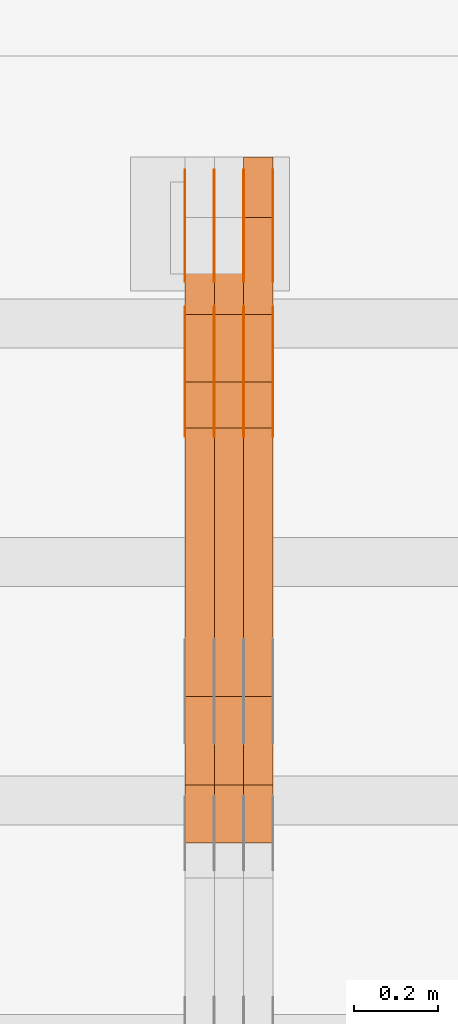
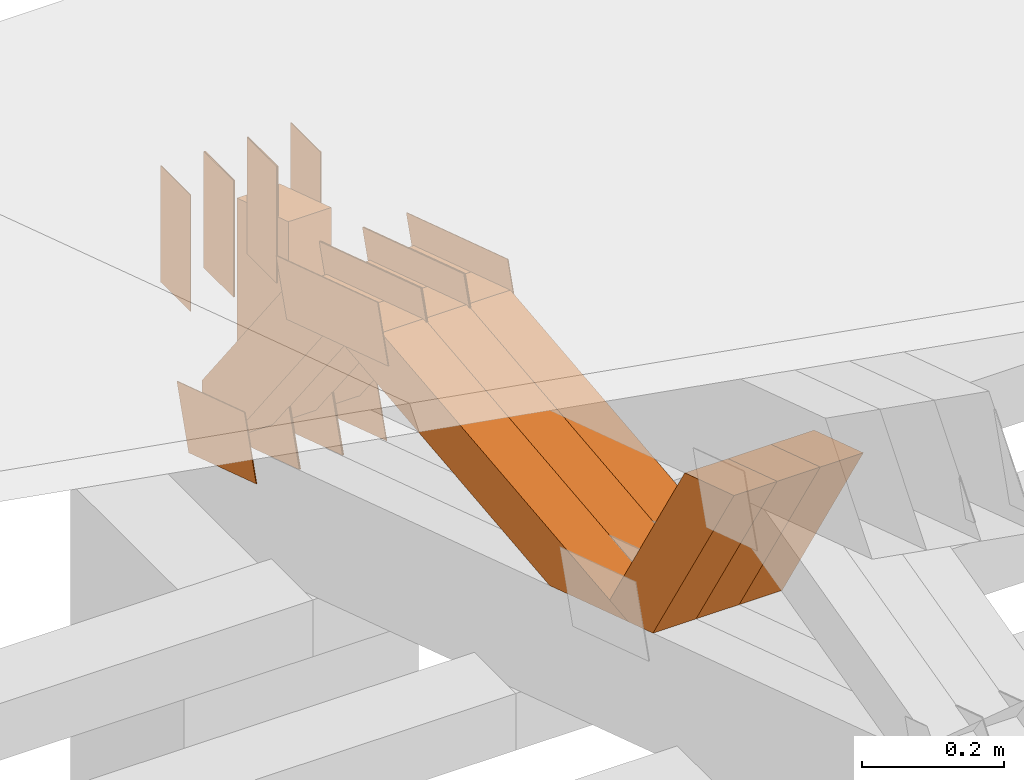
# One storey, part 219 of 385: 28 proxies.
"""IFC2X3 building model written with IfcOpenShell, lengths in millimetres."""

from ifc_helpers import new_model, entity, si_unit, converted_unit, derived_unit, direction, frame, frame_2d, origin, place, context, subcontext, project, spatial, polyline, rectangle, outline, extrude, source, transform, mapped, material, type_object, type_shapes, element, save


model = new_model("IFC2X3")

# Units and contexts
model_context = context("Model", 3, precision=0.01, world=origin(), true_north=direction((6.12303176911189e-17, 1.0)))
body_context = subcontext(model_context, "Body", "Model", "MODEL_VIEW")
ifc_project = project(units=[si_unit("LENGTHUNIT", "METRE", prefix="MILLI"), si_unit("AREAUNIT", "SQUARE_METRE"), si_unit("VOLUMEUNIT", "CUBIC_METRE"), converted_unit("PLANEANGLEUNIT", "DEGREE", entity("IfcRatioMeasure", 0.0174532925199433), si_unit("PLANEANGLEUNIT", "RADIAN"), dimensions=[0, 0, 0, 0, 0, 0, 0]), si_unit("MASSUNIT", "GRAM", prefix="KILO"), derived_unit("MASSDENSITYUNIT", [(si_unit("MASSUNIT", "GRAM", prefix="KILO"), 1), (si_unit("LENGTHUNIT", "METRE"), -3)]), si_unit("TIMEUNIT", "SECOND"), si_unit("FREQUENCYUNIT", "HERTZ"), si_unit("THERMODYNAMICTEMPERATUREUNIT", "DEGREE_CELSIUS"), derived_unit("THERMALTRANSMITTANCEUNIT", [(si_unit("MASSUNIT", "GRAM", prefix="KILO"), 1), (si_unit("THERMODYNAMICTEMPERATUREUNIT", "KELVIN"), -1), (si_unit("TIMEUNIT", "SECOND"), -3)]), derived_unit("VOLUMETRICFLOWRATEUNIT", [(si_unit("LENGTHUNIT", "METRE"), 3), (si_unit("TIMEUNIT", "SECOND"), -1)]), si_unit("ELECTRICCURRENTUNIT", "AMPERE"), si_unit("ELECTRICVOLTAGEUNIT", "VOLT"), si_unit("POWERUNIT", "WATT"), si_unit("FORCEUNIT", "NEWTON", prefix="KILO"), si_unit("ILLUMINANCEUNIT", "LUX"), si_unit("LUMINOUSFLUXUNIT", "LUMEN"), si_unit("LUMINOUSINTENSITYUNIT", "CANDELA"), derived_unit("USERDEFINED", [(si_unit("MASSUNIT", "GRAM", prefix="KILO"), -1), (si_unit("LENGTHUNIT", "METRE"), -2), (si_unit("TIMEUNIT", "SECOND"), 3), (si_unit("LUMINOUSFLUXUNIT", "LUMEN"), 1)]), derived_unit("LINEARVELOCITYUNIT", [(si_unit("LENGTHUNIT", "METRE"), 1), (si_unit("TIMEUNIT", "SECOND"), -1)]), si_unit("PRESSUREUNIT", "PASCAL"), derived_unit("USERDEFINED", [(si_unit("LENGTHUNIT", "METRE"), -2), (si_unit("MASSUNIT", "GRAM", prefix="KILO"), 1), (si_unit("TIMEUNIT", "SECOND"), -2)])], contexts=[model_context])

# Site, building, storey
site_placement = place(None, origin())
site = spatial("IfcSite", under=ifc_project, at=site_placement, CompositionType="ELEMENT")
building_placement = place(site_placement, origin())
building = spatial("IfcBuilding", under=site, at=building_placement, CompositionType="ELEMENT")
storey_placement = place(building_placement, origin())
storey = spatial("IfcBuildingStorey", under=building, at=storey_placement, Name="Default", CompositionType="ELEMENT", Elevation=0.0)

# Proxies
ifc_material_1 = material(Name="IfcSurfaceStyle #240494")
building_element_proxy_type_1 = type_object("IfcBuildingElementProxyType", PredefinedType="NOTDEFINED", material=ifc_material_1)
shared_shape_1 = source(origin(), body_context, "Body", "SweptSolid", [
    extrude(outline(polyline([(-100.000024997547, -54.0000105875654), (100.000088940899, -54.0000105875654), (99.9999100805868, 54.0000105875654), (-99.9999740239394, 54.0000105875654), (-100.000024997547, -54.0000105875654)])), frame((100.000088940899, 54.0000474633838, 0.0), z_axis=(0.0, 0.0, 1.0), x_axis=(-1.0, 0.0, 0.0)), (0.0, 0.0, 1.0), 1.3),
])
type_shapes(building_element_proxy_type_1, [shared_shape_1])
proxy_1_placement = place(building_placement, frame((18386.3, 26390.6212638563, 73.3227520411355), z_axis=(-1.0, 0.0, 0.0), x_axis=(0.0, -0.951056516295124, 0.309016994375039)))
element("IfcBuildingElementProxy", 1, at=proxy_1_placement, inside=storey, type_object=building_element_proxy_type_1, material=ifc_material_1, context=body_context, shape_type="MappedRepresentation", body=[
    mapped(shared_shape_1, transform((0.0, 0.0, 0.0), scale=1.0)),
])
ifc_material_2 = material(Name="IfcSurfaceStyle #240437")
building_element_proxy_type_2 = type_object("IfcBuildingElementProxyType", PredefinedType="NOTDEFINED", material=ifc_material_2)
shared_shape_2 = source(origin(), body_context, "Body", "SweptSolid", [
    extrude(outline(polyline([(-100.000024997547, -54.0000105875654), (100.000088940899, -54.0000105875654), (99.9999100805868, 54.0000105875654), (-99.9999740239394, 54.0000105875654), (-100.000024997547, -54.0000105875654)])), frame((100.000088940899, 54.0000474633838, 0.0), z_axis=(0.0, 0.0, 1.0), x_axis=(-1.0, 0.0, 0.0)), (0.0, 0.0, 1.0), 1.3),
])
type_shapes(building_element_proxy_type_2, [shared_shape_2])
proxy_2_placement = place(building_placement, frame((18315.0, 26390.6212638563, 73.3227520411355), z_axis=(-1.0, 0.0, 0.0), x_axis=(0.0, -0.951056516295124, 0.309016994375039)))
element("IfcBuildingElementProxy", 2, at=proxy_2_placement, inside=storey, type_object=building_element_proxy_type_2, material=ifc_material_2, context=body_context, shape_type="MappedRepresentation", body=[
    mapped(shared_shape_2, transform((0.0, 0.0, 0.0), scale=1.0)),
])
ifc_material_3 = material(Name="IfcSurfaceStyle #240380")
building_element_proxy_type_3 = type_object("IfcBuildingElementProxyType", PredefinedType="NOTDEFINED", material=ifc_material_3)
shared_shape_3 = source(origin(), body_context, "Body", "SweptSolid", [
    extrude(outline(polyline([(-100.000024997547, -54.0000105875654), (100.000088940899, -54.0000105875654), (99.9999100805868, 54.0000105875654), (-99.9999740239394, 54.0000105875654), (-100.000024997547, -54.0000105875654)])), frame((100.000088940899, 54.0000474633838, 0.0), z_axis=(0.0, 0.0, 1.0), x_axis=(-1.0, 0.0, 0.0)), (0.0, 0.0, 1.0), 1.3),
])
type_shapes(building_element_proxy_type_3, [shared_shape_3])
proxy_3_placement = place(building_placement, frame((18316.3, 26390.6212638563, 73.3227520411355), z_axis=(-1.0, 0.0, 0.0), x_axis=(0.0, -0.951056516295124, 0.309016994375039)))
element("IfcBuildingElementProxy", 3, at=proxy_3_placement, inside=storey, type_object=building_element_proxy_type_3, material=ifc_material_3, context=body_context, shape_type="MappedRepresentation", body=[
    mapped(shared_shape_3, transform((0.0, 0.0, 0.0), scale=1.0)),
])
ifc_material_4 = material(Name="IfcSurfaceStyle #240323")
building_element_proxy_type_4 = type_object("IfcBuildingElementProxyType", PredefinedType="NOTDEFINED", material=ifc_material_4)
shared_shape_4 = source(origin(), body_context, "Body", "SweptSolid", [
    extrude(outline(polyline([(-100.000024997547, -54.0000105875654), (100.000088940899, -54.0000105875654), (99.9999100805868, 54.0000105875654), (-99.9999740239394, 54.0000105875654), (-100.000024997547, -54.0000105875654)])), frame((100.000088940899, 54.0000474633838, 0.0), z_axis=(0.0, 0.0, 1.0), x_axis=(-1.0, 0.0, 0.0)), (0.0, 0.0, 1.0), 1.29999999999998),
])
type_shapes(building_element_proxy_type_4, [shared_shape_4])
proxy_4_placement = place(building_placement, frame((18245.0, 26390.6212638563, 73.3227520411355), z_axis=(-1.0, 0.0, 0.0), x_axis=(0.0, -0.951056516295124, 0.309016994375039)))
element("IfcBuildingElementProxy", 4, at=proxy_4_placement, inside=storey, type_object=building_element_proxy_type_4, material=ifc_material_4, context=body_context, shape_type="MappedRepresentation", body=[
    mapped(shared_shape_4, transform((0.0, 0.0, 0.0), scale=1.0)),
])
ifc_material_5 = material(Name="IfcSurfaceStyle #240266")
building_element_proxy_type_5 = type_object("IfcBuildingElementProxyType", PredefinedType="NOTDEFINED", material=ifc_material_5)
shared_shape_5 = source(origin(), body_context, "Body", "SweptSolid", [
    extrude(outline(polyline([(-100.000024997547, -54.0000105875654), (100.000088940899, -54.0000105875654), (99.9999100805868, 54.0000105875654), (-99.9999740239394, 54.0000105875654), (-100.000024997547, -54.0000105875654)])), frame((100.000088940899, 54.0000474633838, 0.0), z_axis=(0.0, 0.0, 1.0), x_axis=(-1.0, 0.0, 0.0)), (0.0, 0.0, 1.0), 1.29999999999998),
])
type_shapes(building_element_proxy_type_5, [shared_shape_5])
proxy_5_placement = place(building_placement, frame((18246.3, 26390.6212638563, 73.3227520411355), z_axis=(-1.0, 0.0, 0.0), x_axis=(0.0, -0.951056516295124, 0.309016994375039)))
element("IfcBuildingElementProxy", 5, at=proxy_5_placement, inside=storey, type_object=building_element_proxy_type_5, material=ifc_material_5, context=body_context, shape_type="MappedRepresentation", body=[
    mapped(shared_shape_5, transform((0.0, 0.0, 0.0), scale=1.0)),
])
ifc_material_6 = material(Name="IfcSurfaceStyle #240209")
building_element_proxy_type_6 = type_object("IfcBuildingElementProxyType", PredefinedType="NOTDEFINED", material=ifc_material_6)
shared_shape_6 = source(origin(), body_context, "Body", "SweptSolid", [
    extrude(outline(polyline([(-100.000024997547, -54.0000105875654), (100.000088940899, -54.0000105875654), (99.9999100805868, 54.0000105875654), (-99.9999740239394, 54.0000105875654), (-100.000024997547, -54.0000105875654)])), frame((100.000088940899, 54.0000474633838, 0.0), z_axis=(0.0, 0.0, 1.0), x_axis=(-1.0, 0.0, 0.0)), (0.0, 0.0, 1.0), 1.29999999999999),
])
type_shapes(building_element_proxy_type_6, [shared_shape_6])
proxy_6_placement = place(building_placement, frame((18175.0, 26390.6212638563, 73.3227520411355), z_axis=(-1.0, 0.0, 0.0), x_axis=(0.0, -0.951056516295124, 0.309016994375039)))
element("IfcBuildingElementProxy", 6, at=proxy_6_placement, inside=storey, type_object=building_element_proxy_type_6, material=ifc_material_6, context=body_context, shape_type="MappedRepresentation", body=[
    mapped(shared_shape_6, transform((0.0, 0.0, 0.0), scale=1.0)),
])
ifc_material_7 = material(Name="IfcSurfaceStyle #227840")
building_element_proxy_type_7 = type_object("IfcBuildingElementProxyType", PredefinedType="NOTDEFINED", material=ifc_material_7)
shared_shape_7 = source(origin(), body_context, "Body", "SweptSolid", [
    extrude(outline(polyline([(-149.999901061401, -48.0000057587028), (150.000035297123, -48.0000057587028), (149.999910491851, 48.0000057587028), (-150.000044727574, 48.0000057587028), (-149.999901061401, -48.0000057587028)])), frame((150.000035297123, 48.0000632585775, 0.0), z_axis=(0.0, 0.0, 1.0), x_axis=(-1.0, 0.0, 0.0)), (0.0, 0.0, 1.0), 1.29999999999999),
])
type_shapes(building_element_proxy_type_7, [shared_shape_7])
proxy_7_placement = place(building_placement, frame((18386.3, 26115.0176968219, 469.58296924555), z_axis=(-1.0, 0.0, 0.0), x_axis=(0.0, -0.951056516295154, 0.309016994374948)))
element("IfcBuildingElementProxy", 7, at=proxy_7_placement, inside=storey, type_object=building_element_proxy_type_7, material=ifc_material_7, context=body_context, shape_type="MappedRepresentation", body=[
    mapped(shared_shape_7, transform((0.0, 0.0, 0.0), scale=1.0)),
])
ifc_material_8 = material(Name="IfcSurfaceStyle #227783")
building_element_proxy_type_8 = type_object("IfcBuildingElementProxyType", PredefinedType="NOTDEFINED", material=ifc_material_8)
shared_shape_8 = source(origin(), body_context, "Body", "SweptSolid", [
    extrude(outline(polyline([(-149.999901061401, -48.0000057587028), (150.000035297123, -48.0000057587028), (149.999910491851, 48.0000057587028), (-150.000044727574, 48.0000057587028), (-149.999901061401, -48.0000057587028)])), frame((150.000035297123, 48.0000632585775, 0.0), z_axis=(0.0, 0.0, 1.0), x_axis=(-1.0, 0.0, 0.0)), (0.0, 0.0, 1.0), 1.29999999999999),
])
type_shapes(building_element_proxy_type_8, [shared_shape_8])
proxy_8_placement = place(building_placement, frame((18315.0, 26115.0176968219, 469.58296924555), z_axis=(-1.0, 0.0, 0.0), x_axis=(0.0, -0.951056516295154, 0.309016994374948)))
element("IfcBuildingElementProxy", 8, at=proxy_8_placement, inside=storey, type_object=building_element_proxy_type_8, material=ifc_material_8, context=body_context, shape_type="MappedRepresentation", body=[
    mapped(shared_shape_8, transform((0.0, 0.0, 0.0), scale=1.0)),
])
ifc_material_9 = material(Name="IfcSurfaceStyle #227726")
building_element_proxy_type_9 = type_object("IfcBuildingElementProxyType", PredefinedType="NOTDEFINED", material=ifc_material_9)
shared_shape_9 = source(origin(), body_context, "Body", "SweptSolid", [
    extrude(outline(polyline([(-149.999901061401, -48.0000057587028), (150.000035297123, -48.0000057587028), (149.999910491851, 48.0000057587028), (-150.000044727574, 48.0000057587028), (-149.999901061401, -48.0000057587028)])), frame((150.000035297123, 48.0000632585775, 0.0), z_axis=(0.0, 0.0, 1.0), x_axis=(-1.0, 0.0, 0.0)), (0.0, 0.0, 1.0), 1.29999999999999),
])
type_shapes(building_element_proxy_type_9, [shared_shape_9])
proxy_9_placement = place(building_placement, frame((18316.3, 26115.0176968219, 469.58296924555), z_axis=(-1.0, 0.0, 0.0), x_axis=(0.0, -0.951056516295154, 0.309016994374948)))
element("IfcBuildingElementProxy", 9, at=proxy_9_placement, inside=storey, type_object=building_element_proxy_type_9, material=ifc_material_9, context=body_context, shape_type="MappedRepresentation", body=[
    mapped(shared_shape_9, transform((0.0, 0.0, 0.0), scale=1.0)),
])
ifc_material_10 = material(Name="IfcSurfaceStyle #227669")
building_element_proxy_type_10 = type_object("IfcBuildingElementProxyType", PredefinedType="NOTDEFINED", material=ifc_material_10)
shared_shape_10 = source(origin(), body_context, "Body", "SweptSolid", [
    extrude(outline(polyline([(-149.999901061401, -48.0000057587028), (150.000035297123, -48.0000057587028), (149.999910491851, 48.0000057587028), (-150.000044727574, 48.0000057587028), (-149.999901061401, -48.0000057587028)])), frame((150.000035297123, 48.0000632585775, 0.0), z_axis=(0.0, 0.0, 1.0), x_axis=(-1.0, 0.0, 0.0)), (0.0, 0.0, 1.0), 1.29999999999998),
])
type_shapes(building_element_proxy_type_10, [shared_shape_10])
proxy_10_placement = place(building_placement, frame((18245.0, 26115.0176968219, 469.58296924555), z_axis=(-1.0, 0.0, 0.0), x_axis=(0.0, -0.951056516295154, 0.309016994374948)))
element("IfcBuildingElementProxy", 10, at=proxy_10_placement, inside=storey, type_object=building_element_proxy_type_10, material=ifc_material_10, context=body_context, shape_type="MappedRepresentation", body=[
    mapped(shared_shape_10, transform((0.0, 0.0, 0.0), scale=1.0)),
])
ifc_material_11 = material(Name="IfcSurfaceStyle #227612")
building_element_proxy_type_11 = type_object("IfcBuildingElementProxyType", PredefinedType="NOTDEFINED", material=ifc_material_11)
shared_shape_11 = source(origin(), body_context, "Body", "SweptSolid", [
    extrude(outline(polyline([(-149.999901061401, -48.0000057587028), (150.000035297123, -48.0000057587028), (149.999910491851, 48.0000057587028), (-150.000044727574, 48.0000057587028), (-149.999901061401, -48.0000057587028)])), frame((150.000035297123, 48.0000632585775, 0.0), z_axis=(0.0, 0.0, 1.0), x_axis=(-1.0, 0.0, 0.0)), (0.0, 0.0, 1.0), 1.29999999999998),
])
type_shapes(building_element_proxy_type_11, [shared_shape_11])
proxy_11_placement = place(building_placement, frame((18246.3, 26115.0176968219, 469.58296924555), z_axis=(-1.0, 0.0, 0.0), x_axis=(0.0, -0.951056516295154, 0.309016994374948)))
element("IfcBuildingElementProxy", 11, at=proxy_11_placement, inside=storey, type_object=building_element_proxy_type_11, material=ifc_material_11, context=body_context, shape_type="MappedRepresentation", body=[
    mapped(shared_shape_11, transform((0.0, 0.0, 0.0), scale=1.0)),
])
ifc_material_12 = material(Name="IfcSurfaceStyle #227555")
building_element_proxy_type_12 = type_object("IfcBuildingElementProxyType", PredefinedType="NOTDEFINED", material=ifc_material_12)
shared_shape_12 = source(origin(), body_context, "Body", "SweptSolid", [
    extrude(outline(polyline([(-149.999901061401, -48.0000057587028), (150.000035297123, -48.0000057587028), (149.999910491851, 48.0000057587028), (-150.000044727574, 48.0000057587028), (-149.999901061401, -48.0000057587028)])), frame((150.000035297123, 48.0000632585775, 0.0), z_axis=(0.0, 0.0, 1.0), x_axis=(-1.0, 0.0, 0.0)), (0.0, 0.0, 1.0), 1.29999999999998),
])
type_shapes(building_element_proxy_type_12, [shared_shape_12])
proxy_12_placement = place(building_placement, frame((18175.0, 26115.0176968219, 469.58296924555), z_axis=(-1.0, 0.0, 0.0), x_axis=(0.0, -0.951056516295154, 0.309016994374948)))
element("IfcBuildingElementProxy", 12, at=proxy_12_placement, inside=storey, type_object=building_element_proxy_type_12, material=ifc_material_12, context=body_context, shape_type="MappedRepresentation", body=[
    mapped(shared_shape_12, transform((0.0, 0.0, 0.0), scale=1.0)),
])
ifc_material_13 = material(Name="IfcSurfaceStyle #227498")
building_element_proxy_type_13 = type_object("IfcBuildingElementProxyType", PredefinedType="NOTDEFINED", material=ifc_material_13)
shared_shape_13 = source(origin(), body_context, "Body", "SweptSolid", [
    extrude(rectangle(XDim=200.0, YDim=84.0000000000005, at=frame_2d((-2.1316282072803e-14, 1.06581410364015e-14), x_axis=(1.0, 0.0))), frame((100.0, 42.0, 0.0), z_axis=(0.0, 0.0, 1.0), x_axis=(-1.0, 0.0, 0.0)), (0.0, 0.0, 1.0), 1.3),
])
type_shapes(building_element_proxy_type_13, [shared_shape_13])
proxy_13_placement = place(building_placement, frame((18386.3, 26469.5000000002, 518.521545410156), z_axis=(-1.0, 0.0, 0.0), x_axis=(0.0, 0.0, -1.0)))
element("IfcBuildingElementProxy", 13, at=proxy_13_placement, inside=storey, type_object=building_element_proxy_type_13, material=ifc_material_13, context=body_context, shape_type="MappedRepresentation", body=[
    mapped(shared_shape_13, transform((0.0, 0.0, 0.0), scale=1.0)),
])
ifc_material_14 = material(Name="IfcSurfaceStyle #227441")
building_element_proxy_type_14 = type_object("IfcBuildingElementProxyType", PredefinedType="NOTDEFINED", material=ifc_material_14)
shared_shape_14 = source(origin(), body_context, "Body", "SweptSolid", [
    extrude(rectangle(XDim=200.0, YDim=84.0000000000005, at=frame_2d((-2.1316282072803e-14, 1.06581410364015e-14), x_axis=(1.0, 0.0))), frame((100.0, 42.0, 0.0), z_axis=(0.0, 0.0, 1.0), x_axis=(-1.0, 0.0, 0.0)), (0.0, 0.0, 1.0), 1.3),
])
type_shapes(building_element_proxy_type_14, [shared_shape_14])
proxy_14_placement = place(building_placement, frame((18315.0, 26469.5000000002, 518.521545410156), z_axis=(-1.0, 0.0, 0.0), x_axis=(0.0, 0.0, -1.0)))
element("IfcBuildingElementProxy", 14, at=proxy_14_placement, inside=storey, type_object=building_element_proxy_type_14, material=ifc_material_14, context=body_context, shape_type="MappedRepresentation", body=[
    mapped(shared_shape_14, transform((0.0, 0.0, 0.0), scale=1.0)),
])
ifc_material_15 = material(Name="IfcSurfaceStyle #227384")
building_element_proxy_type_15 = type_object("IfcBuildingElementProxyType", PredefinedType="NOTDEFINED", material=ifc_material_15)
shared_shape_15 = source(origin(), body_context, "Body", "SweptSolid", [
    extrude(rectangle(XDim=200.0, YDim=84.0000000000005, at=frame_2d((-2.1316282072803e-14, 1.06581410364015e-14), x_axis=(1.0, 0.0))), frame((100.0, 42.0, 0.0), z_axis=(0.0, 0.0, 1.0), x_axis=(-1.0, 0.0, 0.0)), (0.0, 0.0, 1.0), 1.3),
])
type_shapes(building_element_proxy_type_15, [shared_shape_15])
proxy_15_placement = place(building_placement, frame((18316.3, 26469.5000000002, 518.521545410156), z_axis=(-1.0, 0.0, 0.0), x_axis=(0.0, 0.0, -1.0)))
element("IfcBuildingElementProxy", 15, at=proxy_15_placement, inside=storey, type_object=building_element_proxy_type_15, material=ifc_material_15, context=body_context, shape_type="MappedRepresentation", body=[
    mapped(shared_shape_15, transform((0.0, 0.0, 0.0), scale=1.0)),
])
ifc_material_16 = material(Name="IfcSurfaceStyle #227327")
building_element_proxy_type_16 = type_object("IfcBuildingElementProxyType", PredefinedType="NOTDEFINED", material=ifc_material_16)
shared_shape_16 = source(origin(), body_context, "Body", "SweptSolid", [
    extrude(rectangle(XDim=200.0, YDim=84.0000000000005, at=frame_2d((-2.1316282072803e-14, 1.06581410364015e-14), x_axis=(1.0, 0.0))), frame((100.0, 42.0, 0.0), z_axis=(0.0, 0.0, 1.0), x_axis=(-1.0, 0.0, 0.0)), (0.0, 0.0, 1.0), 1.29999999999998),
])
type_shapes(building_element_proxy_type_16, [shared_shape_16])
proxy_16_placement = place(building_placement, frame((18245.0, 26469.5000000002, 518.521545410156), z_axis=(-1.0, 0.0, 0.0), x_axis=(0.0, 0.0, -1.0)))
element("IfcBuildingElementProxy", 16, at=proxy_16_placement, inside=storey, type_object=building_element_proxy_type_16, material=ifc_material_16, context=body_context, shape_type="MappedRepresentation", body=[
    mapped(shared_shape_16, transform((0.0, 0.0, 0.0), scale=1.0)),
])
ifc_material_17 = material(Name="IfcSurfaceStyle #227270")
building_element_proxy_type_17 = type_object("IfcBuildingElementProxyType", PredefinedType="NOTDEFINED", material=ifc_material_17)
shared_shape_17 = source(origin(), body_context, "Body", "SweptSolid", [
    extrude(rectangle(XDim=200.0, YDim=84.0000000000005, at=frame_2d((-2.1316282072803e-14, 1.06581410364015e-14), x_axis=(1.0, 0.0))), frame((100.0, 42.0, 0.0), z_axis=(0.0, 0.0, 1.0), x_axis=(-1.0, 0.0, 0.0)), (0.0, 0.0, 1.0), 1.29999999999998),
])
type_shapes(building_element_proxy_type_17, [shared_shape_17])
proxy_17_placement = place(building_placement, frame((18246.3, 26469.5000000002, 518.521545410156), z_axis=(-1.0, 0.0, 0.0), x_axis=(0.0, 0.0, -1.0)))
element("IfcBuildingElementProxy", 17, at=proxy_17_placement, inside=storey, type_object=building_element_proxy_type_17, material=ifc_material_17, context=body_context, shape_type="MappedRepresentation", body=[
    mapped(shared_shape_17, transform((0.0, 0.0, 0.0), scale=1.0)),
])
ifc_material_18 = material(Name="IfcSurfaceStyle #227213")
building_element_proxy_type_18 = type_object("IfcBuildingElementProxyType", PredefinedType="NOTDEFINED", material=ifc_material_18)
shared_shape_18 = source(origin(), body_context, "Body", "SweptSolid", [
    extrude(rectangle(XDim=200.0, YDim=84.0000000000005, at=frame_2d((-2.1316282072803e-14, 1.06581410364015e-14), x_axis=(1.0, 0.0))), frame((100.0, 42.0, 0.0), z_axis=(0.0, 0.0, 1.0), x_axis=(-1.0, 0.0, 0.0)), (0.0, 0.0, 1.0), 1.29999999999999),
])
type_shapes(building_element_proxy_type_18, [shared_shape_18])
proxy_18_placement = place(building_placement, frame((18175.0, 26469.5000000002, 518.521545410156), z_axis=(-1.0, 0.0, 0.0), x_axis=(0.0, 0.0, -1.0)))
element("IfcBuildingElementProxy", 18, at=proxy_18_placement, inside=storey, type_object=building_element_proxy_type_18, material=ifc_material_18, context=body_context, shape_type="MappedRepresentation", body=[
    mapped(shared_shape_18, transform((0.0, 0.0, 0.0), scale=1.0)),
])
ifc_material_19 = material(Name="IfcSurfaceStyle #216482")
building_element_proxy_type_19 = type_object("IfcBuildingElementProxyType", Name="T1-W31 216480", PredefinedType="NOTDEFINED", material=ifc_material_19)
shared_shape_19 = source(origin(), body_context, "Body", "SweptSolid", [
    extrude(outline(polyline([(-201.245318299844, -47.5000121670808), (204.413774229459, -47.5000121670808), (182.034306640891, 5.35692244583164e-05), (126.70380769348, 47.4999853824686), (-311.906570263987, 47.4999853824686), (-201.245318299844, -47.5000121670808)])), frame((204.413774229459, 47.5002684334588, 0.0), z_axis=(0.0, 0.0, 1.0), x_axis=(-1.0, 0.0, 0.0)), (0.0, 0.0, 1.0), 70.0),
])
type_shapes(building_element_proxy_type_19, [shared_shape_19])
proxy_19_placement = place(building_placement, frame((18385.0, 25127.5652647985, 487.27008059185), z_axis=(-1.0, 0.0, 0.0), x_axis=(0.0, -0.520333970303023, 0.853962855953755)))
element("IfcBuildingElementProxy", 19, at=proxy_19_placement, inside=storey, type_object=building_element_proxy_type_19, material=ifc_material_19, Name="T1-W31", context=body_context, shape_type="MappedRepresentation", body=[
    mapped(shared_shape_19, transform((0.0, 0.0, 0.0), scale=1.0)),
])
ifc_material_20 = material(Name="IfcSurfaceStyle #216416")
building_element_proxy_type_20 = type_object("IfcBuildingElementProxyType", Name="T1-W31 216414", PredefinedType="NOTDEFINED", material=ifc_material_20)
shared_shape_20 = source(origin(), body_context, "Body", "SweptSolid", [
    extrude(outline(polyline([(-201.245318299844, -47.5000121670808), (204.413774229459, -47.5000121670808), (182.034306640891, 5.35692244583164e-05), (126.70380769348, 47.4999853824686), (-311.906570263987, 47.4999853824686), (-201.245318299844, -47.5000121670808)])), frame((204.413774229459, 47.5002684334588, 0.0), z_axis=(0.0, 0.0, 1.0), x_axis=(-1.0, 0.0, 0.0)), (0.0, 0.0, 1.0), 70.0),
])
type_shapes(building_element_proxy_type_20, [shared_shape_20])
proxy_20_placement = place(building_placement, frame((18315.0, 25127.5652647985, 487.27008059185), z_axis=(-1.0, 0.0, 0.0), x_axis=(0.0, -0.520333970303023, 0.853962855953755)))
element("IfcBuildingElementProxy", 20, at=proxy_20_placement, inside=storey, type_object=building_element_proxy_type_20, material=ifc_material_20, Name="T1-W31", context=body_context, shape_type="MappedRepresentation", body=[
    mapped(shared_shape_20, transform((0.0, 0.0, 0.0), scale=1.0)),
])
ifc_material_21 = material(Name="IfcSurfaceStyle #216350")
building_element_proxy_type_21 = type_object("IfcBuildingElementProxyType", Name="T1-W31 216348", PredefinedType="NOTDEFINED", material=ifc_material_21)
shared_shape_21 = source(origin(), body_context, "Body", "SweptSolid", [
    extrude(outline(polyline([(-201.245318299844, -47.5000121670808), (204.413774229459, -47.5000121670808), (182.034306640891, 5.35692244583164e-05), (126.70380769348, 47.4999853824686), (-311.906570263987, 47.4999853824686), (-201.245318299844, -47.5000121670808)])), frame((204.413774229459, 47.5002684334588, 0.0), z_axis=(0.0, 0.0, 1.0), x_axis=(-1.0, 0.0, 0.0)), (0.0, 0.0, 1.0), 70.0),
])
type_shapes(building_element_proxy_type_21, [shared_shape_21])
proxy_21_placement = place(building_placement, frame((18245.0, 25127.5652647985, 487.27008059185), z_axis=(-1.0, 0.0, 0.0), x_axis=(0.0, -0.520333970303023, 0.853962855953755)))
element("IfcBuildingElementProxy", 21, at=proxy_21_placement, inside=storey, type_object=building_element_proxy_type_21, material=ifc_material_21, Name="T1-W31", context=body_context, shape_type="MappedRepresentation", body=[
    mapped(shared_shape_21, transform((0.0, 0.0, 0.0), scale=1.0)),
])
ifc_material_22 = material(Name="IfcSurfaceStyle #216086")
building_element_proxy_type_22 = type_object("IfcBuildingElementProxyType", Name="T1-W4 216084", PredefinedType="NOTDEFINED", material=ifc_material_22)
shared_shape_22 = source(origin(), body_context, "Body", "SweptSolid", [
    extrude(outline(polyline([(-510.077325435179, -47.4999981284922), (188.854793418912, -47.4999981284922), (294.906688207675, 1.67015383116809e-05), (324.289382923648, 47.499989777723), (-297.973539115057, 47.4999897777231), (-510.077325435179, -47.4999981284922)])), frame((324.289382923648, 47.5000278316275, 0.0), z_axis=(0.0, 0.0, 1.0), x_axis=(-1.0, 0.0, 0.0)), (0.0, 0.0, 1.0), 70.0),
])
type_shapes(building_element_proxy_type_22, [shared_shape_22])
proxy_22_placement = place(building_placement, frame((18385.0, 25996.2241251556, 525.69905884318), z_axis=(-1.0, 0.0, 0.0), x_axis=(0.0, -0.994287125203057, -0.106738524701444)))
element("IfcBuildingElementProxy", 22, at=proxy_22_placement, inside=storey, type_object=building_element_proxy_type_22, material=ifc_material_22, Name="T1-W4", context=body_context, shape_type="MappedRepresentation", body=[
    mapped(shared_shape_22, transform((0.0, 0.0, 0.0), scale=1.0)),
])
ifc_material_23 = material(Name="IfcSurfaceStyle #216020")
building_element_proxy_type_23 = type_object("IfcBuildingElementProxyType", Name="T1-W4 216018", PredefinedType="NOTDEFINED", material=ifc_material_23)
shared_shape_23 = source(origin(), body_context, "Body", "SweptSolid", [
    extrude(outline(polyline([(-510.077325435179, -47.4999981284922), (188.854793418912, -47.4999981284922), (294.906688207675, 1.67015383116809e-05), (324.289382923648, 47.499989777723), (-297.973539115057, 47.4999897777231), (-510.077325435179, -47.4999981284922)])), frame((324.289382923648, 47.5000278316275, 0.0), z_axis=(0.0, 0.0, 1.0), x_axis=(-1.0, 0.0, 0.0)), (0.0, 0.0, 1.0), 70.0),
])
type_shapes(building_element_proxy_type_23, [shared_shape_23])
proxy_23_placement = place(building_placement, frame((18315.0, 25996.2241251556, 525.69905884318), z_axis=(-1.0, 0.0, 0.0), x_axis=(0.0, -0.994287125203057, -0.106738524701444)))
element("IfcBuildingElementProxy", 23, at=proxy_23_placement, inside=storey, type_object=building_element_proxy_type_23, material=ifc_material_23, Name="T1-W4", context=body_context, shape_type="MappedRepresentation", body=[
    mapped(shared_shape_23, transform((0.0, 0.0, 0.0), scale=1.0)),
])
ifc_material_24 = material(Name="IfcSurfaceStyle #215954")
building_element_proxy_type_24 = type_object("IfcBuildingElementProxyType", Name="T1-W4 215952", PredefinedType="NOTDEFINED", material=ifc_material_24)
shared_shape_24 = source(origin(), body_context, "Body", "SweptSolid", [
    extrude(outline(polyline([(-510.077325435179, -47.4999981284922), (188.854793418912, -47.4999981284922), (294.906688207675, 1.67015383116809e-05), (324.289382923648, 47.499989777723), (-297.973539115057, 47.4999897777231), (-510.077325435179, -47.4999981284922)])), frame((324.289382923648, 47.5000278316275, 0.0), z_axis=(0.0, 0.0, 1.0), x_axis=(-1.0, 0.0, 0.0)), (0.0, 0.0, 1.0), 70.0),
])
type_shapes(building_element_proxy_type_24, [shared_shape_24])
proxy_24_placement = place(building_placement, frame((18245.0, 25996.2241251556, 525.69905884318), z_axis=(-1.0, 0.0, 0.0), x_axis=(0.0, -0.994287125203057, -0.106738524701444)))
element("IfcBuildingElementProxy", 24, at=proxy_24_placement, inside=storey, type_object=building_element_proxy_type_24, material=ifc_material_24, Name="T1-W4", context=body_context, shape_type="MappedRepresentation", body=[
    mapped(shared_shape_24, transform((0.0, 0.0, 0.0), scale=1.0)),
])
ifc_material_25 = material(Name="IfcSurfaceStyle #215690")
building_element_proxy_type_25 = type_object("IfcBuildingElementProxyType", Name="T1-W21 215688", PredefinedType="NOTDEFINED", material=ifc_material_25)
shared_shape_25 = source(origin(), body_context, "Body", "SweptSolid", [
    extrude(outline(polyline([(-209.199362597501, -47.5000308982766), (168.813164734153, -47.5000308982766), (229.900717355638, -2.18385470334148e-05), (159.828709317766, 47.5000418175501), (-349.343228810055, 47.5000418175502), (-209.199362597501, -47.5000308982766)])), frame((229.900720156071, 47.5000418175501, 0.0), z_axis=(0.0, 0.0, 1.0), x_axis=(-1.0, 0.0, 0.0)), (0.0, 0.0, 1.0), 70.0),
])
type_shapes(building_element_proxy_type_25, [shared_shape_25])
proxy_25_placement = place(building_placement, frame((18385.0, 26317.5019908272, 112.518372832984), z_axis=(-1.0, 0.0, 0.0), x_axis=(0.0, -0.613839629272042, 0.789430750310097)))
element("IfcBuildingElementProxy", 25, at=proxy_25_placement, inside=storey, type_object=building_element_proxy_type_25, material=ifc_material_25, Name="T1-W21", context=body_context, shape_type="MappedRepresentation", body=[
    mapped(shared_shape_25, transform((0.0, 0.0, 0.0), scale=1.0)),
])
ifc_material_26 = material(Name="IfcSurfaceStyle #215624")
building_element_proxy_type_26 = type_object("IfcBuildingElementProxyType", Name="T1-W21 215622", PredefinedType="NOTDEFINED", material=ifc_material_26)
shared_shape_26 = source(origin(), body_context, "Body", "SweptSolid", [
    extrude(outline(polyline([(-209.199362597501, -47.5000308982766), (168.813164734153, -47.5000308982766), (229.900717355638, -2.18385470334148e-05), (159.828709317766, 47.5000418175501), (-349.343228810055, 47.5000418175502), (-209.199362597501, -47.5000308982766)])), frame((229.900720156071, 47.5000418175501, 0.0), z_axis=(0.0, 0.0, 1.0), x_axis=(-1.0, 0.0, 0.0)), (0.0, 0.0, 1.0), 70.0),
])
type_shapes(building_element_proxy_type_26, [shared_shape_26])
proxy_26_placement = place(building_placement, frame((18315.0, 26317.5019908272, 112.518372832984), z_axis=(-1.0, 0.0, 0.0), x_axis=(0.0, -0.613839629272042, 0.789430750310097)))
element("IfcBuildingElementProxy", 26, at=proxy_26_placement, inside=storey, type_object=building_element_proxy_type_26, material=ifc_material_26, Name="T1-W21", context=body_context, shape_type="MappedRepresentation", body=[
    mapped(shared_shape_26, transform((0.0, 0.0, 0.0), scale=1.0)),
])
ifc_material_27 = material(Name="IfcSurfaceStyle #215558")
building_element_proxy_type_27 = type_object("IfcBuildingElementProxyType", Name="T1-W21 215556", PredefinedType="NOTDEFINED", material=ifc_material_27)
shared_shape_27 = source(origin(), body_context, "Body", "SweptSolid", [
    extrude(outline(polyline([(-209.199362597501, -47.5000308982766), (168.813164734153, -47.5000308982766), (229.900717355638, -2.18385470334148e-05), (159.828709317766, 47.5000418175501), (-349.343228810055, 47.5000418175502), (-209.199362597501, -47.5000308982766)])), frame((229.900720156071, 47.5000418175501, 0.0), z_axis=(0.0, 0.0, 1.0), x_axis=(-1.0, 0.0, 0.0)), (0.0, 0.0, 1.0), 70.0),
])
type_shapes(building_element_proxy_type_27, [shared_shape_27])
proxy_27_placement = place(building_placement, frame((18245.0, 26317.5019908272, 112.518372832984), z_axis=(-1.0, 0.0, 0.0), x_axis=(0.0, -0.613839629272042, 0.789430750310097)))
element("IfcBuildingElementProxy", 27, at=proxy_27_placement, inside=storey, type_object=building_element_proxy_type_27, material=ifc_material_27, Name="T1-W21", context=body_context, shape_type="MappedRepresentation", body=[
    mapped(shared_shape_27, transform((0.0, 0.0, 0.0), scale=1.0)),
])
ifc_material_28 = material(Name="IfcSurfaceStyle #215123")
building_element_proxy_type_28 = type_object("IfcBuildingElementProxyType", Name="T1-E2 215121", PredefinedType="NOTDEFINED", material=ifc_material_28)
shared_shape_28 = source(origin(), body_context, "Body", "SweptSolid", [
    extrude(outline(polyline([(-126.644535064697, -72.4999999999998), (173.757884979248, -72.4999999999998), (126.644542694092, 72.4999999999998), (-173.757892608642, 72.4999999999998), (-126.644535064697, -72.4999999999998)])), frame((173.757890653796, 72.5000000000002, 0.0), z_axis=(0.0, 0.0, 1.0), x_axis=(-1.0, 0.0, 0.0)), (0.0, 0.0, 1.0), 70.0),
])
type_shapes(building_element_proxy_type_28, [shared_shape_28])
proxy_28_placement = place(building_placement, frame((18385.0, 26500.0, 442.078222227283), z_axis=(-1.0, 0.0, 0.0), x_axis=(0.0, 0.0, -1.0)))
element("IfcBuildingElementProxy", 28, at=proxy_28_placement, inside=storey, type_object=building_element_proxy_type_28, material=ifc_material_28, Name="T1-E2", context=body_context, shape_type="MappedRepresentation", body=[
    mapped(shared_shape_28, transform((0.0, 0.0, 0.0), scale=1.0)),
])

save(model, "model.ifc")
